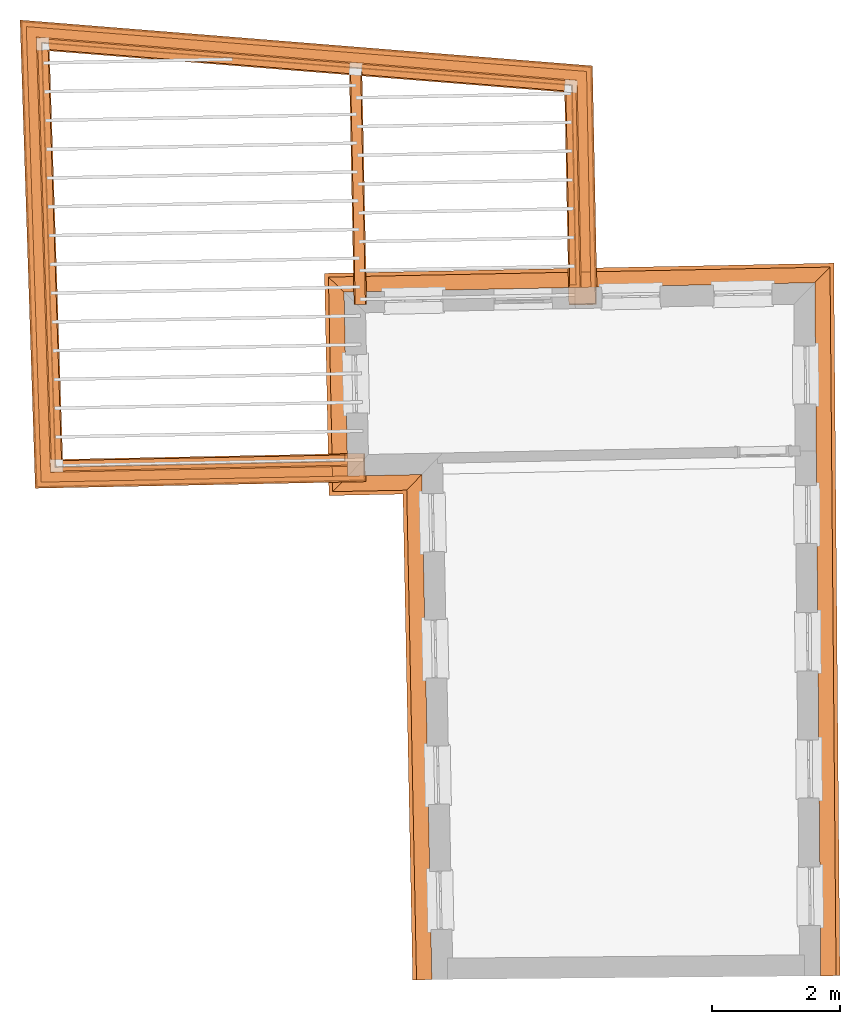
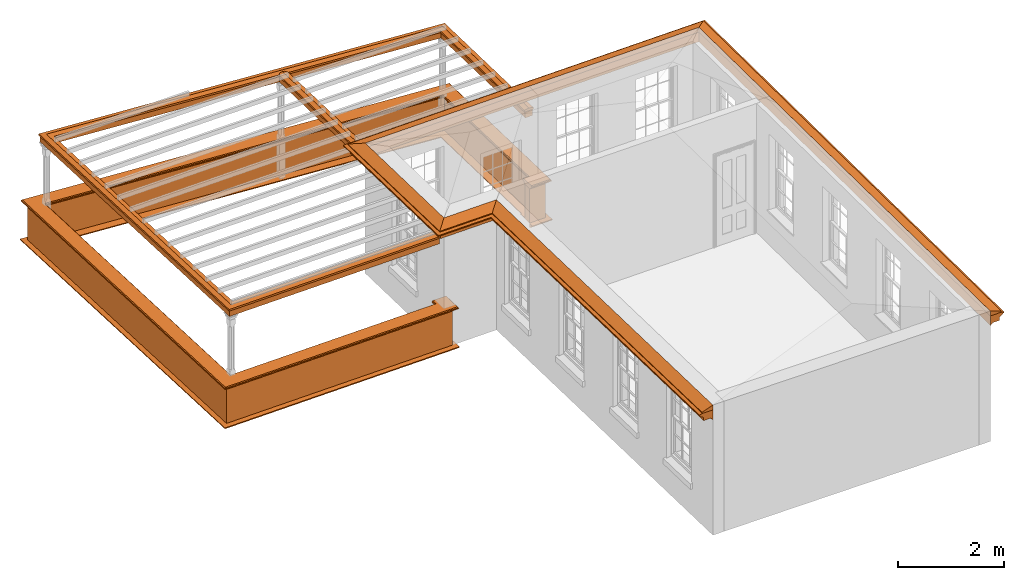
# One storey, part 10 of 11: 9 proxies.
"""IFC2X3 building model written with IfcOpenShell, lengths in metres."""

from ifc_helpers import new_model, entity, si_unit, frame, origin, place, context, subcontext, project, spatial, element, save


model = new_model("IFC2X3")

# Units and contexts
model_context = context("Model", 3, world=origin())
body_context = subcontext(model_context, "Body", "Model", "MODEL_VIEW")
ifc_project = project(units=[si_unit("PLANEANGLEUNIT", "RADIAN"), si_unit("MASSUNIT", "GRAM", prefix="KILO"), si_unit("FORCEUNIT", "NEWTON", prefix="KILO"), si_unit("LENGTHUNIT", "METRE")], contexts=[model_context])

# Site, building, storey
site_placement = place(None, origin())
site = spatial("IfcSite", under=ifc_project, at=site_placement, CompositionType="ELEMENT")
building_placement = place(None, origin())
building = spatial("IfcBuilding", under=site, at=building_placement, Name="Building plot-11", CompositionType="ELEMENT")
storey_placement = place(None, frame((0.0, 0.0, 5.3)))
storey = spatial("IfcBuildingStorey", under=building, at=storey_placement, Name="Floor 1", CompositionType="ELEMENT", Elevation=5.3)

# Proxies
proxy_1_placement = place(storey_placement, frame((0.0, 0.0, 3.0)))
axis2_placement3_d_1 = entity("IfcAxis2Placement3D", entity("IfcCartesianPoint", [0.0, 0.0, 0.0]))
element("IfcBuildingElementProxy", 1, at=proxy_1_placement, inside=storey, Name="eaves", CompositionType="ELEMENT", context=body_context, shape_type="SweptSolid", held_by="IfcProductRepresentation", body=[
    entity("IfcSurfaceCurveSweptAreaSolid", entity("IfcArbitraryClosedProfileDef", "AREA", None, entity("IfcPolyline", [entity("IfcCartesianPoint", [-0.11, 0.25]), entity("IfcCartesianPoint", [-0.33, 0.25]), entity("IfcCartesianPoint", [-0.33, 0.265]), entity("IfcCartesianPoint", [-0.318, 0.268]), entity("IfcCartesianPoint", [-0.309, 0.274]), entity("IfcCartesianPoint", [-0.303, 0.283]), entity("IfcCartesianPoint", [-0.3, 0.295]), entity("IfcCartesianPoint", [-0.285, 0.295]), entity("IfcCartesianPoint", [-0.285, 0.455]), entity("IfcCartesianPoint", [-0.205, 0.455]), entity("IfcCartesianPoint", [-0.205, 0.47]), entity("IfcCartesianPoint", [-0.19, 0.47]), entity("IfcCartesianPoint", [-0.189, 0.483]), entity("IfcCartesianPoint", [-0.186, 0.494]), entity("IfcCartesianPoint", [-0.179, 0.506]), entity("IfcCartesianPoint", [-0.17, 0.514]), entity("IfcCartesianPoint", [-0.16, 0.52]), entity("IfcCartesianPoint", [-0.149, 0.529]), entity("IfcCartesianPoint", [-0.143, 0.539]), entity("IfcCartesianPoint", [-0.14, 0.55]), entity("IfcCartesianPoint", [-0.12, 0.55]), entity("IfcCartesianPoint", [-0.11, 0.48]), entity("IfcCartesianPoint", [-0.11, 0.25])])), axis2_placement3_d_1, entity("IfcPolyline", [entity("IfcCartesianPoint", [65.6637585802534, 12.2186759944661]), entity("IfcCartesianPoint", [65.5731109786296, 22.8002401432746]), entity("IfcCartesianPoint", [58.7182673203823, 22.6631666918127]), entity("IfcCartesianPoint", [58.7657377764171, 20.289238326885]), entity("IfcCartesianPoint", [59.9229233916632, 20.3123780853058]), entity("IfcCartesianPoint", [60.0858019869711, 12.1670567688703])]), 0.0, 1.0, entity("IfcPlane", axis2_placement3_d_1)),
])
proxy_2_placement = place(storey_placement, frame((0.0, 0.0, 3.0)))
axis2_placement3_d_2 = entity("IfcAxis2Placement3D", entity("IfcCartesianPoint", [0.0, 0.0, 0.0]))
element("IfcBuildingElementProxy", 2, at=proxy_2_placement, inside=storey, Name="eaves", CompositionType="ELEMENT", context=body_context, shape_type="SweptSolid", held_by="IfcProductRepresentation", body=[
    entity("IfcSurfaceCurveSweptAreaSolid", entity("IfcArbitraryClosedProfileDef", "AREA", None, entity("IfcPolyline", [entity("IfcCartesianPoint", [-0.11, 0.25]), entity("IfcCartesianPoint", [-0.11, 0.48]), entity("IfcCartesianPoint", [-0.08, 0.49]), entity("IfcCartesianPoint", [0.0, 0.25]), entity("IfcCartesianPoint", [-0.11, 0.25])])), axis2_placement3_d_2, entity("IfcPolyline", [entity("IfcCartesianPoint", [65.6637585802534, 12.2186759944661]), entity("IfcCartesianPoint", [65.5731109786296, 22.8002401432746]), entity("IfcCartesianPoint", [58.7182673203823, 22.6631666918127]), entity("IfcCartesianPoint", [58.7657377764171, 20.289238326885]), entity("IfcCartesianPoint", [59.9229233916632, 20.3123780853058]), entity("IfcCartesianPoint", [60.0858019869711, 12.1670567688703])]), 0.0, 1.0, entity("IfcPlane", axis2_placement3_d_2)),
])
proxy_3_placement = place(storey_placement, origin())
axis2_placement3_d_3 = entity("IfcAxis2Placement3D", entity("IfcCartesianPoint", [0.0, 0.0, 0.0]))
element("IfcBuildingElementProxy", 3, at=proxy_3_placement, inside=storey, Name="parapet", CompositionType="ELEMENT", context=body_context, shape_type="SweptSolid", held_by="IfcProductRepresentation", body=[
    entity("IfcSurfaceCurveSweptAreaSolid", entity("IfcArbitraryClosedProfileDef", "AREA", None, entity("IfcPolyline", [entity("IfcCartesianPoint", [0.0, 0.25]), entity("IfcCartesianPoint", [0.795, 0.25]), entity("IfcCartesianPoint", [0.795, 0.09]), entity("IfcCartesianPoint", [0.02, 0.09]), entity("IfcCartesianPoint", [0.02, -0.08]), entity("IfcCartesianPoint", [0.0, -0.08]), entity("IfcCartesianPoint", [0.0, 0.25])])), axis2_placement3_d_3, entity("IfcPolyline", [entity("IfcCartesianPoint", [61.9696569377765, 23.0382453474009]), entity("IfcCartesianPoint", [62.0696369506034, 23.0402446060446]), entity("IfcCartesianPoint", [62.0079202467552, 26.1266070742675]), entity("IfcCartesianPoint", [53.754980550035, 26.7871639157067]), entity("IfcCartesianPoint", [53.9697987685744, 20.1933359335438]), entity("IfcCartesianPoint", [58.4557997366536, 20.2830406250893]), entity("IfcCartesianPoint", [58.4538004780098, 20.3830206379163])]), 0.0, 1.0, entity("IfcPlane", axis2_placement3_d_3)),
])
proxy_4_placement = place(storey_placement, origin())
axis2_placement3_d_4 = entity("IfcAxis2Placement3D", entity("IfcCartesianPoint", [0.0, 0.0, 0.0]))
element("IfcBuildingElementProxy", 4, at=proxy_4_placement, inside=storey, Name="parapet", CompositionType="ELEMENT", context=body_context, shape_type="SweptSolid", held_by="IfcProductRepresentation", body=[
    entity("IfcSurfaceCurveSweptAreaSolid", entity("IfcArbitraryClosedProfileDef", "AREA", None, entity("IfcPolyline", [entity("IfcCartesianPoint", [0.795, 0.265]), entity("IfcCartesianPoint", [0.807, 0.268]), entity("IfcCartesianPoint", [0.816, 0.274]), entity("IfcCartesianPoint", [0.822, 0.283]), entity("IfcCartesianPoint", [0.825, 0.295]), entity("IfcCartesianPoint", [0.84, 0.295]), entity("IfcCartesianPoint", [0.84, 0.305]), entity("IfcCartesianPoint", [0.842, 0.317]), entity("IfcCartesianPoint", [0.849, 0.326]), entity("IfcCartesianPoint", [0.858, 0.333]), entity("IfcCartesianPoint", [0.87, 0.335]), entity("IfcCartesianPoint", [0.882, 0.333]), entity("IfcCartesianPoint", [0.891, 0.326]), entity("IfcCartesianPoint", [0.898, 0.317]), entity("IfcCartesianPoint", [0.9, 0.305]), entity("IfcCartesianPoint", [0.9, 0.035]), entity("IfcCartesianPoint", [0.898, 0.023]), entity("IfcCartesianPoint", [0.891, 0.014]), entity("IfcCartesianPoint", [0.882, 0.007]), entity("IfcCartesianPoint", [0.87, 0.005]), entity("IfcCartesianPoint", [0.858, 0.007]), entity("IfcCartesianPoint", [0.849, 0.014]), entity("IfcCartesianPoint", [0.842, 0.023]), entity("IfcCartesianPoint", [0.84, 0.035]), entity("IfcCartesianPoint", [0.84, 0.045]), entity("IfcCartesianPoint", [0.825, 0.045]), entity("IfcCartesianPoint", [0.822, 0.057]), entity("IfcCartesianPoint", [0.816, 0.066]), entity("IfcCartesianPoint", [0.807, 0.072]), entity("IfcCartesianPoint", [0.795, 0.075]), entity("IfcCartesianPoint", [0.795, 0.265])])), axis2_placement3_d_4, entity("IfcPolyline", [entity("IfcCartesianPoint", [61.9696569377765, 23.0382453474009]), entity("IfcCartesianPoint", [62.0696369506034, 23.0402446060446]), entity("IfcCartesianPoint", [62.0079202467552, 26.1266070742675]), entity("IfcCartesianPoint", [53.754980550035, 26.7871639157067]), entity("IfcCartesianPoint", [53.9697987685744, 20.1933359335438]), entity("IfcCartesianPoint", [58.4557997366536, 20.2830406250893]), entity("IfcCartesianPoint", [58.4538004780098, 20.3830206379163])]), 0.0, 1.0, entity("IfcPlane", axis2_placement3_d_4)),
])
proxy_5_placement = place(storey_placement, origin())
axis2_placement3_d_5 = entity("IfcAxis2Placement3D", entity("IfcCartesianPoint", [0.0, 0.0, 0.0]))
element("IfcBuildingElementProxy", 5, at=proxy_5_placement, inside=storey, Name="parapet", CompositionType="ELEMENT", context=body_context, shape_type="SweptSolid", held_by="IfcProductRepresentation", body=[
    entity("IfcSurfaceCurveSweptAreaSolid", entity("IfcArbitraryClosedProfileDef", "AREA", None, entity("IfcPolyline", [entity("IfcCartesianPoint", [-0.1, 0.25]), entity("IfcCartesianPoint", [-0.1, 0.265]), entity("IfcCartesianPoint", [-0.085, 0.265]), entity("IfcCartesianPoint", [-0.084, 0.278]), entity("IfcCartesianPoint", [-0.081, 0.289]), entity("IfcCartesianPoint", [-0.074, 0.301]), entity("IfcCartesianPoint", [-0.065, 0.309]), entity("IfcCartesianPoint", [-0.055, 0.315]), entity("IfcCartesianPoint", [-0.044, 0.324]), entity("IfcCartesianPoint", [-0.038, 0.334]), entity("IfcCartesianPoint", [-0.035, 0.345]), entity("IfcCartesianPoint", [-0.015, 0.345]), entity("IfcCartesianPoint", [0.0, 0.25]), entity("IfcCartesianPoint", [-0.1, 0.25])])), axis2_placement3_d_5, entity("IfcPolyline", [entity("IfcCartesianPoint", [61.9696569377765, 23.0382453474009]), entity("IfcCartesianPoint", [62.0696369506034, 23.0402446060446]), entity("IfcCartesianPoint", [62.0079202467552, 26.1266070742675]), entity("IfcCartesianPoint", [53.754980550035, 26.7871639157067]), entity("IfcCartesianPoint", [53.9697987685744, 20.1933359335438]), entity("IfcCartesianPoint", [58.4557997366536, 20.2830406250893]), entity("IfcCartesianPoint", [58.4538004780098, 20.3830206379163])]), 0.0, 1.0, entity("IfcPlane", axis2_placement3_d_5)),
])
proxy_6_placement = place(storey_placement, frame((0.0, 0.0, 3.0)))
axis2_placement3_d_6 = entity("IfcAxis2Placement3D", entity("IfcCartesianPoint", [0.0, 0.0, 0.0]))
element("IfcBuildingElementProxy", 6, at=proxy_6_placement, inside=storey, Name="pergola beam", CompositionType="ELEMENT", context=body_context, shape_type="SweptSolid", held_by="IfcProductRepresentation", body=[
    entity("IfcSurfaceCurveSweptAreaSolid", entity("IfcArbitraryClosedProfileDef", "AREA", None, entity("IfcPolyline", [entity("IfcCartesianPoint", [-0.7, -0.08]), entity("IfcCartesianPoint", [-0.7, 0.08]), entity("IfcCartesianPoint", [-0.56, 0.08]), entity("IfcCartesianPoint", [-0.56, -0.08]), entity("IfcCartesianPoint", [-0.7, -0.08])])), axis2_placement3_d_6, entity("IfcPolyline", [entity("IfcCartesianPoint", [62.0708365057897, 22.9802565983485]), entity("IfcCartesianPoint", [62.0079202467552, 26.1266070742675]), entity("IfcCartesianPoint", [53.754980550035, 26.7871639157067]), entity("IfcCartesianPoint", [53.9697987685744, 20.1933359335438]), entity("IfcCartesianPoint", [58.5157877443497, 20.2842401802756])]), 0.0, 1.0, entity("IfcPlane", axis2_placement3_d_6)),
])
proxy_7_placement = place(storey_placement, frame((0.0, 0.0, 3.0)))
axis2_placement3_d_7 = entity("IfcAxis2Placement3D", entity("IfcCartesianPoint", [0.0, 0.0, 0.0]))
element("IfcBuildingElementProxy", 7, at=proxy_7_placement, inside=storey, Name="pergola beam", CompositionType="ELEMENT", context=body_context, shape_type="SweptSolid", held_by="IfcProductRepresentation", body=[
    entity("IfcSurfaceCurveSweptAreaSolid", entity("IfcArbitraryClosedProfileDef", "AREA", None, entity("IfcPolyline", [entity("IfcCartesianPoint", [-0.5, 0.0]), entity("IfcCartesianPoint", [-0.52, -0.1]), entity("IfcCartesianPoint", [-0.56, -0.1]), entity("IfcCartesianPoint", [-0.56, 0.1]), entity("IfcCartesianPoint", [-0.52, 0.1]), entity("IfcCartesianPoint", [-0.5, 0.0])])), axis2_placement3_d_7, entity("IfcPolyline", [entity("IfcCartesianPoint", [62.0708365057897, 22.9802565983485]), entity("IfcCartesianPoint", [62.0079202467552, 26.1266070742675]), entity("IfcCartesianPoint", [53.754980550035, 26.7871639157067]), entity("IfcCartesianPoint", [53.9697987685744, 20.1933359335438]), entity("IfcCartesianPoint", [58.5157877443497, 20.2842401802756])]), 0.0, 1.0, entity("IfcPlane", axis2_placement3_d_7)),
])
proxy_8_placement = place(storey_placement, frame((0.0, 0.0, 3.0)))
axis2_placement3_d_8 = entity("IfcAxis2Placement3D", entity("IfcCartesianPoint", [0.0, 0.0, 0.0]))
element("IfcBuildingElementProxy", 8, at=proxy_8_placement, inside=storey, Name="pergola beam", CompositionType="ELEMENT", context=body_context, shape_type="SweptSolid", held_by="IfcProductRepresentation", body=[
    entity("IfcSurfaceCurveSweptAreaSolid", entity("IfcArbitraryClosedProfileDef", "AREA", None, entity("IfcPolyline", [entity("IfcCartesianPoint", [-0.7, -0.08]), entity("IfcCartesianPoint", [-0.7, 0.08]), entity("IfcCartesianPoint", [-0.56, 0.08]), entity("IfcCartesianPoint", [-0.56, -0.08]), entity("IfcCartesianPoint", [-0.7, -0.08])])), axis2_placement3_d_8, entity("IfcPolyline", [entity("IfcCartesianPoint", [58.7172676910604, 22.7131566982262]), entity("IfcCartesianPoint", [58.6446254023501, 26.3458917521365])]), 0.0, 1.0, entity("IfcPlane", axis2_placement3_d_8)),
])
proxy_9_placement = place(storey_placement, frame((0.0, 0.0, 3.0)))
axis2_placement3_d_9 = entity("IfcAxis2Placement3D", entity("IfcCartesianPoint", [0.0, 0.0, 0.0]))
element("IfcBuildingElementProxy", 9, at=proxy_9_placement, inside=storey, Name="pergola beam", CompositionType="ELEMENT", context=body_context, shape_type="SweptSolid", held_by="IfcProductRepresentation", body=[
    entity("IfcSurfaceCurveSweptAreaSolid", entity("IfcArbitraryClosedProfileDef", "AREA", None, entity("IfcPolyline", [entity("IfcCartesianPoint", [-0.5, 0.0]), entity("IfcCartesianPoint", [-0.52, -0.1]), entity("IfcCartesianPoint", [-0.56, -0.1]), entity("IfcCartesianPoint", [-0.56, 0.1]), entity("IfcCartesianPoint", [-0.52, 0.1]), entity("IfcCartesianPoint", [-0.5, 0.0])])), axis2_placement3_d_9, entity("IfcPolyline", [entity("IfcCartesianPoint", [58.7172676910604, 22.7131566982262]), entity("IfcCartesianPoint", [58.6446254023501, 26.3458917521365])]), 0.0, 1.0, entity("IfcPlane", axis2_placement3_d_9)),
])

save(model, "model.ifc")
